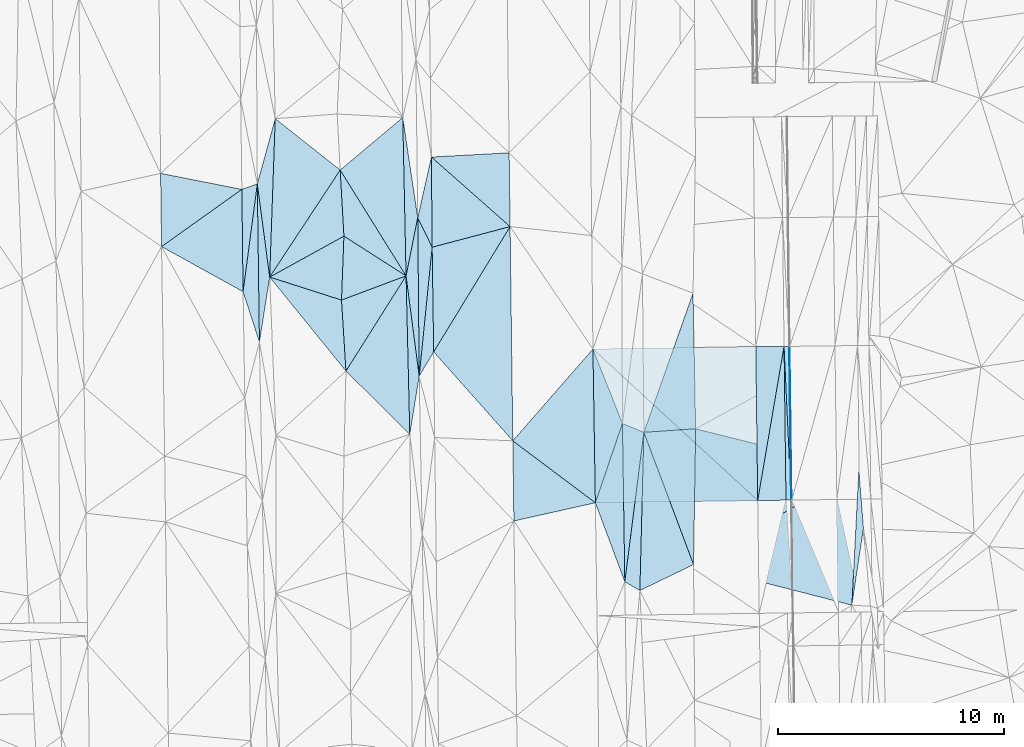
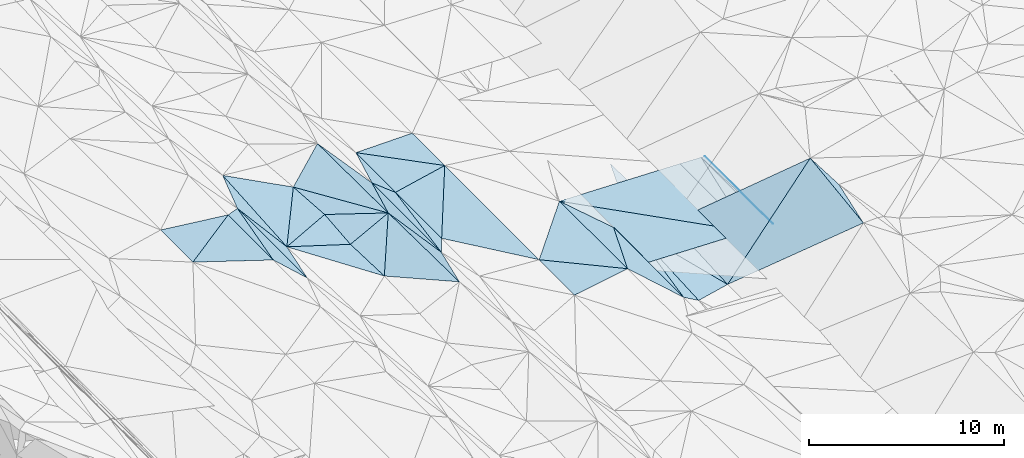
# One storey, part 33 of 275: 45 plates.
"""IFC2X3 building model written with IfcOpenShell, lengths in millimetres."""

from ifc_helpers import new_model, si_unit, frame, origin_with_axes, place, context, subcontext, project, spatial, polyline, outline, extrude, material, type_object, element, save


model = new_model("IFC2X3")

# Units and contexts
model_context = context("Model", 3, precision=1e-05, world=origin_with_axes())
body_context = subcontext(model_context, "Body", "Model", "MODEL_VIEW")
ifc_project = project(units=[si_unit("LENGTHUNIT", "METRE", prefix="MILLI"), si_unit("AREAUNIT", "SQUARE_METRE"), si_unit("VOLUMEUNIT", "CUBIC_METRE"), si_unit("MASSUNIT", "GRAM", prefix="KILO"), si_unit("TIMEUNIT", "SECOND"), si_unit("PLANEANGLEUNIT", "RADIAN"), si_unit("SOLIDANGLEUNIT", "STERADIAN"), si_unit("THERMODYNAMICTEMPERATUREUNIT", "DEGREE_CELSIUS"), si_unit("LUMINOUSINTENSITYUNIT", "LUMEN")], contexts=[model_context])

# Site, building, storey
site_placement = place(None, origin_with_axes())
site = spatial("IfcSite", under=ifc_project, at=site_placement, CompositionType="ELEMENT")
building_placement = place(site_placement, origin_with_axes())
building = spatial("IfcBuilding", under=site, at=building_placement, Name="Undefined", CompositionType="ELEMENT")
storey_placement = place(building_placement, origin_with_axes())
storey = spatial("IfcBuildingStorey", under=building, at=storey_placement, Name="Undefined", CompositionType="ELEMENT", Elevation=0.0)

# Plates
ifc_material = material()
plate_type_1 = type_object("IfcPlateType", PredefinedType="NOTDEFINED")
plate_1_placement = place(storey_placement, frame((-63085.534338525, 8684.36899878103, 41334.5004597078), z_axis=(-0.0369370970163898, 0.0225643102113344, -0.99906281222388), x_axis=(0.0150595045438115, -0.999618950249349, -0.0231336470381295)))
element("IfcPlate", 1, at=plate_1_placement, inside=storey, type_object=plate_type_1, material=ifc_material, Name="00", context=body_context, shape_type="SweptSolid", body=[
    extrude(outline(polyline([(0.0, 0.0), (7002.787109375, -1.11322151497006e-09), (3489.873046875, 1250.12219238281), (0.0, 0.0)])), frame((-8.85201319254618e-08, 2.18876761149539e-07, -0.5000001331573), z_axis=(0.0, 0.0, 1.0), x_axis=(1.0, 0.0, 0.0)), (0.0, 0.0, 1.0), 1.0),
])
plate_type_2 = type_object("IfcPlateType", PredefinedType="NOTDEFINED")
plate_2_placement = place(storey_placement, frame((-83458.0401202355, 16499.1899121102, 41559.5004170445), z_axis=(0.0371128799012044, 0.0190050586107432, -0.999130342794493), x_axis=(-0.0133932936564058, 0.999738796529341, 0.0185191360246058)))
element("IfcPlate", 2, at=plate_2_placement, inside=storey, type_object=plate_type_2, material=ifc_material, Name="00", context=body_context, shape_type="SweptSolid", body=[
    extrude(outline(polyline([(0.0, 0.0), (3239.89208984375, 3.44880390912294e-09), (2486.53344726563, 3585.64501953125), (0.0, 0.0)])), frame((-8.85201319254618e-08, 2.18876761149539e-07, -0.5000001331573), z_axis=(0.0, 0.0, 1.0), x_axis=(1.0, 0.0, 0.0)), (0.0, 0.0, 1.0), 1.0),
])
plate_type_3 = type_object("IfcPlateType", PredefinedType="NOTDEFINED")
plate_3_placement = place(storey_placement, frame((-55606.1009030587, 5293.94394170118, 40996.4907456072), z_axis=(-0.0501822086058736, 0.0211194130225013, -0.998516758163338), x_axis=(-0.0155081560633747, 0.999639384492585, 0.0219225469961935)))
element("IfcPlate", 3, at=plate_3_placement, inside=storey, type_object=plate_type_3, material=ifc_material, Name="00_PR", context=body_context, shape_type="SweptSolid", body=[
    extrude(outline(polyline([(0.0, 0.0), (6798.66259765625, 2.5029294192791e-09), (6798.5703125, 20.0249786376953), (0.0, 0.0)])), frame((-8.85201319254618e-08, 2.18876761149539e-07, -0.5000001331573), z_axis=(0.0, 0.0, 1.0), x_axis=(1.0, 0.0, 0.0)), (0.0, 0.0, 1.0), 1.0),
])
plate_4_placement = place(storey_placement, frame((-55606.1009030587, 5293.94394170118, 40996.4907456072), z_axis=(-0.0502069234273629, 0.0211190024140485, -0.998515524454675), x_axis=(-0.998666208743383, -0.0131185270511445, 0.0499370379790979)))
element("IfcPlate", 4, at=plate_4_placement, inside=storey, type_object=plate_type_3, material=ifc_material, Name="00_PR", context=body_context, shape_type="SweptSolid", body=[
    extrude(outline(polyline([(0.0, 0.0), (20.0252170562744, 7.18500814400613e-11), (23.5806293487549, 6798.62158203125), (0.0, 0.0)])), frame((-8.85201319254618e-08, 2.18876761149539e-07, -0.5000001331573), z_axis=(0.0, 0.0, 1.0), x_axis=(1.0, 0.0, 0.0)), (0.0, 0.0, 1.0), 1.0),
])
plate_type_4 = type_object("IfcPlateType", PredefinedType="NOTDEFINED")
plate_5_placement = place(storey_placement, frame((-57106.0315624464, 5279.47807770141, 41051.4944035738), z_axis=(-0.0338549393769678, 0.0212811578278257, -0.999200157826894), x_axis=(-0.0125651770635663, 0.999685189745127, 0.0217172219588593)))
element("IfcPlate", 5, at=plate_5_placement, inside=storey, type_object=plate_type_4, material=ifc_material, Name="00_PR", context=body_context, shape_type="SweptSolid", body=[
    extrude(outline(polyline([(0.0, 0.0), (6809.388671875, 3.63797880709171e-10), (6793.43310546875, 1250.69665527344), (0.0, 0.0)])), frame((-8.85201319254618e-08, 2.18876761149539e-07, -0.5000001331573), z_axis=(0.0, 0.0, 1.0), x_axis=(1.0, 0.0, 0.0)), (0.0, 0.0, 1.0), 1.0),
])
plate_type_5 = type_object("IfcPlateType", PredefinedType="NOTDEFINED")
plate_6_placement = place(storey_placement, frame((-55941.5115161613, 12087.3947260162, 41157.0344094784), z_axis=(-0.0341675188866801, 0.0213344424915223, -0.999188381746257), x_axis=(0.0125666940571451, -0.999683901046901, -0.0217755869754435)))
element("IfcPlate", 6, at=plate_6_placement, inside=storey, type_object=plate_type_5, material=ifc_material, Name="00_PR", context=body_context, shape_type="SweptSolid", body=[
    extrude(outline(polyline([(0.0, 0.0), (6798.88427734375, -6.12635631114244e-09), (6793.4287109375, 1250.72106933594), (0.0, 0.0)])), frame((-8.85201319254618e-08, 2.18876761149539e-07, -0.5000001331573), z_axis=(0.0, 0.0, 1.0), x_axis=(1.0, 0.0, 0.0)), (0.0, 0.0, 1.0), 1.0),
])
plate_type_6 = type_object("IfcPlateType", PredefinedType="NOTDEFINED")
plate_7_placement = place(storey_placement, frame((-55711.5356229066, 12090.1548382223, 41145.5347451969), z_axis=(-0.0501822086058736, 0.0211194130225013, -0.998516758163338), x_axis=(0.0125666940571451, -0.999683901046901, -0.0217755869754435)))
element("IfcPlate", 7, at=plate_7_placement, inside=storey, type_object=plate_type_6, material=ifc_material, Name="00_PR", context=body_context, shape_type="SweptSolid", body=[
    extrude(outline(polyline([(0.0, 0.0), (6798.62255859375, -1.54977897182107e-09), (-0.381209224462509, 230.287475585938), (0.0, 0.0)])), frame((-8.85201319254618e-08, 2.18876761149539e-07, -0.5000001331573), z_axis=(0.0, 0.0, 1.0), x_axis=(1.0, 0.0, 0.0)), (0.0, 0.0, 1.0), 1.0),
])
plate_8_placement = place(storey_placement, frame((-55856.0791666298, 5290.65935581579, 41008.9907460628), z_axis=(-0.0502076607453631, 0.0211181487987247, -0.99851550543484), x_axis=(-0.0125668220575414, 0.999683917691528, 0.0217747489605038)))
element("IfcPlate", 8, at=plate_8_placement, inside=storey, type_object=plate_type_6, material=ifc_material, Name="00_PR", context=body_context, shape_type="SweptSolid", body=[
    extrude(outline(polyline([(0.0, 0.0), (6798.88427734375, -6.12635631114244e-09), (-0.119594693183899, 230.286880493164), (0.0, 0.0)])), frame((-8.85201319254618e-08, 2.18876761149539e-07, -0.5000001331573), z_axis=(0.0, 0.0, 1.0), x_axis=(1.0, 0.0, 0.0)), (0.0, 0.0, 1.0), 1.0),
])
plate_type_7 = type_object("IfcPlateType", PredefinedType="NOTDEFINED")
plate_9_placement = place(storey_placement, frame((-64389.5860539135, 11972.8997140316, 41439.5003999853), z_axis=(-0.0336700774157678, 0.0212836155691658, -0.999206351858874), x_axis=(0.99931922283272, 0.0158024230601671, -0.0333372809694402)))
element("IfcPlate", 9, at=plate_9_placement, inside=storey, type_object=plate_type_7, material=ifc_material, Name="00_PR", context=body_context, shape_type="SweptSolid", body=[
    extrude(outline(polyline([(0.0, 0.0), (7202.89697265625, -1.26237864606082e-09), (7185.7587890625, 6809.3671875), (0.0, 0.0)])), frame((-8.85201319254618e-08, 2.18876761149539e-07, -0.5000001331573), z_axis=(0.0, 0.0, 1.0), x_axis=(1.0, 0.0, 0.0)), (0.0, 0.0, 1.0), 1.0),
])
plate_type_8 = type_object("IfcPlateType", PredefinedType="NOTDEFINED")
plate_10_placement = place(storey_placement, frame((-57106.0316977267, 5279.47783110151, 41051.4944029285), z_axis=(-0.0341252349844567, 0.020788038246301, -0.999201343975841), x_axis=(-0.999323625483583, -0.0144173130703921, 0.0338294639948438)))
element("IfcPlate", 10, at=plate_10_placement, inside=storey, type_object=plate_type_8, material=ifc_material, Name="00_PR", context=body_context, shape_type="SweptSolid", body=[
    extrude(outline(polyline([(0.0, 0.0), (7180.9296875, -1.59561750479043e-08), (7195.2529296875, 6799.333984375), (0.0, 0.0)])), frame((-8.85201319254618e-08, 2.18876761149539e-07, -0.5000001331573), z_axis=(0.0, 0.0, 1.0), x_axis=(1.0, 0.0, 0.0)), (0.0, 0.0, 1.0), 1.0),
])
plate_type_9 = type_object("IfcPlateType", PredefinedType="NOTDEFINED")
plate_11_placement = place(storey_placement, frame((-64389.5841732302, 11972.8991551249, 41439.5003133719), z_axis=(-0.0297436310834051, 0.0201138443502984, -0.999355166932871), x_axis=(0.368458731692333, -0.929170595276867, -0.0296676239781534)))
element("IfcPlate", 11, at=plate_11_placement, inside=storey, type_object=plate_type_9, material=ifc_material, Name="00", context=body_context, shape_type="SweptSolid", body=[
    extrude(outline(polyline([(0.0, 0.0), (3539.21166992188, -2.46654963120818e-09), (6359.28369140625, 2406.07861328125), (0.0, 0.0)])), frame((-8.85201319254618e-08, 2.18876761149539e-07, -0.5000001331573), z_axis=(0.0, 0.0, 1.0), x_axis=(1.0, 0.0, 0.0)), (0.0, 0.0, 1.0), 1.0),
])
plate_type_10 = type_object("IfcPlateType", PredefinedType="NOTDEFINED")
plate_12_placement = place(storey_placement, frame((-71429.2424392682, 11845.5865518244, 41659.50029753), z_axis=(-0.0293061238153869, 0.0196802600943957, -0.999376724998904), x_axis=(0.520744448360644, 0.853711218239636, 0.00154121814336699)))
element("IfcPlate", 12, at=plate_12_placement, inside=storey, type_object=plate_type_10, material=ifc_material, Name="00", context=body_context, shape_type="SweptSolid", body=[
    extrude(outline(polyline([(0.0, 0.0), (6488.3740234375, 7.42147676646709e-09), (-1534.66796875, 5036.80419921875), (0.0, 0.0)])), frame((-8.85201319254618e-08, 2.18876761149539e-07, -0.5000001331573), z_axis=(0.0, 0.0, 1.0), x_axis=(1.0, 0.0, 0.0)), (0.0, 0.0, 1.0), 1.0),
])
plate_type_11 = type_object("IfcPlateType", PredefinedType="NOTDEFINED")
plate_13_placement = place(storey_placement, frame((-72069.1854004757, 10773.21347745, 41660.5084277943), z_axis=(0.182006470566101, 0.0185295168551531, -0.983122729712413), x_axis=(-0.129940215574496, 0.991507297259225, -0.00536841300199027)))
element("IfcPlate", 13, at=plate_13_placement, inside=storey, type_object=plate_type_11, material=ifc_material, Name="00", context=body_context, shape_type="SweptSolid", body=[
    extrude(outline(polyline([(0.0, 0.0), (4470.5947265625, -5.17320586368442e-09), (6950.0556640625, 860.239990234375), (0.0, 0.0)])), frame((-8.85201319254618e-08, 2.18876761149539e-07, -0.5000001331573), z_axis=(0.0, 0.0, 1.0), x_axis=(1.0, 0.0, 0.0)), (0.0, 0.0, 1.0), 1.0),
])
plate_type_12 = type_object("IfcPlateType", PredefinedType="NOTDEFINED")
plate_14_placement = place(storey_placement, frame((-79854.4320262508, 14506.0956215983, 41639.500168743), z_axis=(0.0156607527350185, 0.0222808532478277, -0.999629083411603), x_axis=(-0.0119464226664534, 0.999684498778123, 0.0220949290156476)))
element("IfcPlate", 14, at=plate_14_placement, inside=storey, type_object=plate_type_12, material=ifc_material, Name="00", context=body_context, shape_type="SweptSolid", body=[
    extrude(outline(polyline([(0.0, 0.0), (4525.92529296875, -4.13274392485619e-09), (4755.61083984375, 686.165100097656), (0.0, 0.0)])), frame((-8.85201319254618e-08, 2.18876761149539e-07, -0.5000001331573), z_axis=(0.0, 0.0, 1.0), x_axis=(1.0, 0.0, 0.0)), (0.0, 0.0, 1.0), 1.0),
])
plate_type_13 = type_object("IfcPlateType", PredefinedType="NOTDEFINED")
plate_15_placement = place(storey_placement, frame((-52943.4534964903, 649.111417036266, 42936.5007921276), z_axis=(-0.0183788980974422, 0.0536330072608011, -0.998391564786525), x_axis=(0.0514689023508599, 0.997287037128105, 0.0526262070364499)))
element("IfcPlate", 15, at=plate_15_placement, inside=storey, type_object=plate_type_13, material=ifc_material, Name="00", context=body_context, shape_type="SweptSolid", body=[
    extrude(outline(polyline([(0.0, 0.0), (6004.61279296875, -1.19325704872608e-09), (3421.61547851563, 335.0791015625), (0.0, 0.0)])), frame((-8.85201319254618e-08, 2.18876761149539e-07, -0.5000001331573), z_axis=(0.0, 0.0, 1.0), x_axis=(1.0, 0.0, 0.0)), (0.0, 0.0, 1.0), 1.0),
])
plate_type_14 = type_object("IfcPlateType", PredefinedType="NOTDEFINED")
plate_16_placement = place(storey_placement, frame((-71496.3066648247, 16473.6746332651, 41749.5002758741), z_axis=(-0.0282335174220587, 0.0190260740692208, -0.999420270456574), x_axis=(0.966533054055638, 0.255558859707056, -0.0224393547837469)))
element("IfcPlate", 16, at=plate_16_placement, inside=storey, type_object=plate_type_14, material=ifc_material, Name="00", context=body_context, shape_type="SweptSolid", body=[
    extrude(outline(polyline([(0.0, 0.0), (3565.16479492188, -1.13504938781261e-09), (-1115.9091796875, 4492.9443359375), (0.0, 0.0)])), frame((-8.85201319254618e-08, 2.18876761149539e-07, -0.5000001331573), z_axis=(0.0, 0.0, 1.0), x_axis=(1.0, 0.0, 0.0)), (0.0, 0.0, 1.0), 1.0),
])
plate_type_15 = type_object("IfcPlateType", PredefinedType="NOTDEFINED")
plate_17_placement = place(storey_placement, frame((-78678.5249739628, 15152.7962430898, 41661.5002095248), z_axis=(-0.0220739810846482, 0.0198987167112959, -0.999558292663474), x_axis=(-0.131654518554041, 0.991037172027586, 0.0226365059995845)))
element("IfcPlate", 17, at=plate_17_placement, inside=storey, type_object=plate_type_15, material=ifc_material, Name="00", context=body_context, shape_type="SweptSolid", body=[
    extrude(outline(polyline([(0.0, 0.0), (4152.58447265625, -2.6338966563344e-09), (6911.16357421875, 1165.56665039063), (0.0, 0.0)])), frame((-8.85201319254618e-08, 2.18876761149539e-07, -0.5000001331573), z_axis=(0.0, 0.0, 1.0), x_axis=(1.0, 0.0, 0.0)), (0.0, 0.0, 1.0), 1.0),
])
plate_type_16 = type_object("IfcPlateType", PredefinedType="NOTDEFINED")
plate_18_placement = place(storey_placement, frame((-72069.293060822, 10773.2136927695, 41660.5003531147), z_axis=(-0.0333102560253779, 0.018949496162916, -0.999265401902165), x_axis=(0.0999993363783862, 0.994866257547555, 0.0155326210667701)))
element("IfcPlate", 18, at=plate_18_placement, inside=storey, type_object=plate_type_16, material=ifc_material, Name="00", context=body_context, shape_type="SweptSolid", body=[
    extrude(outline(polyline([(0.0, 0.0), (5729.87646484375, -3.78349795937538e-09), (1130.85607910156, 529.91552734375), (0.0, 0.0)])), frame((-8.85201319254618e-08, 2.18876761149539e-07, -0.5000001331573), z_axis=(0.0, 0.0, 1.0), x_axis=(1.0, 0.0, 0.0)), (0.0, 0.0, 1.0), 1.0),
])
plate_type_17 = type_object("IfcPlateType", PredefinedType="NOTDEFINED")
plate_19_placement = place(storey_placement, frame((-59849.5582576572, 8447.63962534401, 40652.5106788933), z_axis=(-0.20254727770208, 0.0355374176027969, -0.978627453245412), x_axis=(-0.0152652204527903, -0.999334469653733, -0.0331299080351765)))
element("IfcPlate", 19, at=plate_19_placement, inside=storey, type_object=plate_type_17, material=ifc_material, Name="00", context=body_context, shape_type="SweptSolid", body=[
    extrude(outline(polyline([(0.0, 0.0), (6006.6572265625, -3.71073838323355e-09), (174.953384399414, 2334.4892578125), (0.0, 0.0)])), frame((-8.85201319254618e-08, 2.18876761149539e-07, -0.5000001331573), z_axis=(0.0, 0.0, 1.0), x_axis=(1.0, 0.0, 0.0)), (0.0, 0.0, 1.0), 1.0),
])
plate_type_18 = type_object("IfcPlateType", PredefinedType="NOTDEFINED")
plate_20_placement = place(storey_placement, frame((-79131.5365787582, 12274.8692533166, 41612.5001898718), z_axis=(-0.0200263350420128, 0.0201715959286534, -0.999595944680888), x_axis=(-0.0133936735424026, 0.999701321302467, 0.0204420570183296)))
element("IfcPlate", 20, at=plate_20_placement, inside=storey, type_object=plate_type_18, material=ifc_material, Name="00", context=body_context, shape_type="SweptSolid", body=[
    extrude(outline(polyline([(0.0, 0.0), (6995.3818359375, -9.45874489843845e-10), (2872.00170898438, 491.621978759766), (0.0, 0.0)])), frame((-8.85201319254618e-08, 2.18876761149539e-07, -0.5000001331573), z_axis=(0.0, 0.0, 1.0), x_axis=(1.0, 0.0, 0.0)), (0.0, 0.0, 1.0), 1.0),
])
plate_type_19 = type_object("IfcPlateType", PredefinedType="NOTDEFINED")
plate_21_placement = place(storey_placement, frame((-79225.2070081375, 19268.1621804227, 41755.5002754346), z_axis=(0.0268588396974892, 0.0207962096628469, -0.999422893671024), x_axis=(0.0133936735155429, -0.999701321303435, -0.0204420569886023)))
element("IfcPlate", 21, at=plate_21_placement, inside=storey, type_object=plate_type_19, material=ifc_material, Name="00", context=body_context, shape_type="SweptSolid", body=[
    extrude(outline(polyline([(0.0, 0.0), (6995.3818359375, -9.45874489843845e-10), (4754.5888671875, 693.213134765625), (0.0, 0.0)])), frame((-8.85201319254618e-08, 2.18876761149539e-07, -0.5000001331573), z_axis=(0.0, 0.0, 1.0), x_axis=(1.0, 0.0, 0.0)), (0.0, 0.0, 1.0), 1.0),
])
plate_type_20 = type_object("IfcPlateType", PredefinedType="NOTDEFINED")
plate_22_placement = place(storey_placement, frame((-72484.8295077743, 8201.54507200805, 41516.5107588047), z_axis=(0.205296130925048, 0.0216069404373172, -0.978461362932714), x_axis=(-0.0235832505463294, 0.999575191040927, 0.0171250620192308)))
element("IfcPlate", 22, at=plate_22_placement, inside=storey, type_object=plate_type_20, material=ifc_material, Name="00", context=body_context, shape_type="SweptSolid", body=[
    extrude(outline(polyline([(0.0, 0.0), (7007.27392578125, -2.64844857156277e-09), (2563.24096679688, 486.6083984375), (0.0, 0.0)])), frame((-8.85201319254618e-08, 2.18876761149539e-07, -0.5000001331573), z_axis=(0.0, 0.0, 1.0), x_axis=(1.0, 0.0, 0.0)), (0.0, 0.0, 1.0), 1.0),
])
plate_type_21 = type_object("IfcPlateType", PredefinedType="NOTDEFINED")
plate_23_placement = place(storey_placement, frame((-59964.6036930516, 14443.0792287991, 40761.5102695677), z_axis=(-0.20124539325043, 0.0139450140627032, -0.979441590028865), x_axis=(0.0191821964893445, -0.999650811674886, -0.0181741039830456)))
element("IfcPlate", 23, at=plate_23_placement, inside=storey, type_object=plate_type_21, material=ifc_material, Name="00", context=body_context, shape_type="SweptSolid", body=[
    extrude(outline(polyline([(0.0, 0.0), (5997.54443359375, -4.80213202536106e-10), (6100.7138671875, 2338.76147460938), (0.0, 0.0)])), frame((-8.85201319254618e-08, 2.18876761149539e-07, -0.5000001331573), z_axis=(0.0, 0.0, 1.0), x_axis=(1.0, 0.0, 0.0)), (0.0, 0.0, 1.0), 1.0),
])
plate_type_22 = type_object("IfcPlateType", PredefinedType="NOTDEFINED")
plate_24_placement = place(storey_placement, frame((-75504.037272346, 14137.724360508, 41319.5026273024), z_axis=(-0.094043313671562, 0.0410333595514505, -0.994722131329948), x_axis=(0.0622192225208152, -0.996954880651629, -0.0470078109871342)))
element("IfcPlate", 24, at=plate_24_placement, inside=storey, type_object=plate_type_22, material=ifc_material, Name="00", context=body_context, shape_type="SweptSolid", body=[
    extrude(outline(polyline([(0.0, 0.0), (3148.41284179688, 1.99361238628626e-09), (-1225.58447265625, 3118.15649414063), (0.0, 0.0)])), frame((-8.85201319254618e-08, 2.18876761149539e-07, -0.5000001331573), z_axis=(0.0, 0.0, 1.0), x_axis=(1.0, 0.0, 0.0)), (0.0, 0.0, 1.0), 1.0),
])
plate_type_23 = type_object("IfcPlateType", PredefinedType="NOTDEFINED")
plate_25_placement = place(storey_placement, frame((-62980.1636764046, 1684.24889227149, 41172.5115172295), z_axis=(-0.212600057881091, 0.0194060804486137, -0.976946579619673), x_axis=(-0.0150595045538727, 0.999618950250185, 0.0231336469954438)))
element("IfcPlate", 25, at=plate_25_placement, inside=storey, type_object=plate_type_23, material=ifc_material, Name="00", context=body_context, shape_type="SweptSolid", body=[
    extrude(outline(polyline([(0.0, 0.0), (7002.787109375, -1.11322151497006e-09), (6591.3525390625, 963.507080078125), (0.0, 0.0)])), frame((-8.85201319254618e-08, 2.18876761149539e-07, -0.5000001331573), z_axis=(0.0, 0.0, 1.0), x_axis=(1.0, 0.0, 0.0)), (0.0, 0.0, 1.0), 1.0),
])
plate_type_24 = type_object("IfcPlateType", PredefinedType="NOTDEFINED")
plate_26_placement = place(storey_placement, frame((-72650.1081175779, 15205.8435217715, 41636.5063085416), z_axis=(0.156677870740202, 0.0238569222979481, -0.987361581224825), x_axis=(-0.0208156475431547, 0.999565925843796, 0.0208487100175156)))
element("IfcPlate", 26, at=plate_26_placement, inside=storey, type_object=plate_type_24, material=ifc_material, Name="00", context=body_context, shape_type="SweptSolid", body=[
    extrude(outline(polyline([(0.0, 0.0), (7002.8310546875, -4.00905264541507e-09), (2560.27758789063, 576.815979003906), (0.0, 0.0)])), frame((-8.85201319254618e-08, 2.18876761149539e-07, -0.5000001331573), z_axis=(0.0, 0.0, 1.0), x_axis=(1.0, 0.0, 0.0)), (0.0, 0.0, 1.0), 1.0),
])
plate_type_25 = type_object("IfcPlateType", PredefinedType="NOTDEFINED")
plate_27_placement = place(storey_placement, frame((-62138.082034099, 8292.00736579458, 41120.5176247738), z_axis=(-0.261956410787184, 0.0257922584598766, -0.964734988611398), x_axis=(-0.0252625814544928, -0.999483524766561, -0.0198616640407225)))
element("IfcPlate", 27, at=plate_27_placement, inside=storey, type_object=plate_type_25, material=ifc_material, Name="00", context=body_context, shape_type="SweptSolid", body=[
    extrude(outline(polyline([(0.0, 0.0), (6998.40673828125, -4.39467839896679e-09), (6624.58349609375, 699.407043457031), (0.0, 0.0)])), frame((-8.85201319254618e-08, 2.18876761149539e-07, -0.5000001331573), z_axis=(0.0, 0.0, 1.0), x_axis=(1.0, 0.0, 0.0)), (0.0, 0.0, 1.0), 1.0),
])
plate_type_26 = type_object("IfcPlateType", PredefinedType="NOTDEFINED")
plate_28_placement = place(storey_placement, frame((-72133.9185815669, 17774.9786993754, 41780.5001016621), z_axis=(-0.007797963871655, 0.0199958753442322, -0.999769651834199), x_axis=(0.219018831395588, 0.975558195381218, 0.0178033400981889)))
element("IfcPlate", 28, at=plate_28_placement, inside=storey, type_object=plate_type_26, material=ifc_material, Name="00", context=body_context, shape_type="SweptSolid", body=[
    extrude(outline(polyline([(0.0, 0.0), (2752.29248046875, -6.37373887002468e-09), (-1130.39807128906, 907.256469726563), (0.0, 0.0)])), frame((-8.85201319254618e-08, 2.18876761149539e-07, -0.5000001331573), z_axis=(0.0, 0.0, 1.0), x_axis=(1.0, 0.0, 0.0)), (0.0, 0.0, 1.0), 1.0),
])
plate_29_placement = place(storey_placement, frame((-72069.2833503895, 10773.2127163934, 41660.5001103939), z_axis=(-0.0138991992444694, 0.0170060897767567, -0.999758773490319), x_axis=(-0.00922996353593435, 0.999810576846857, 0.0171352910182584)))
element("IfcPlate", 29, at=plate_29_placement, inside=storey, type_object=plate_type_26, material=ifc_material, Name="00", context=body_context, shape_type="SweptSolid", body=[
    extrude(outline(polyline([(0.0, 0.0), (7003.0908203125, -2.88127921521664e-09), (5695.61767578125, 625.641296386719), (0.0, 0.0)])), frame((-8.85201319254618e-08, 2.18876761149539e-07, -0.5000001331573), z_axis=(0.0, 0.0, 1.0), x_axis=(1.0, 0.0, 0.0)), (0.0, 0.0, 1.0), 1.0),
])
plate_type_27 = type_object("IfcPlateType", PredefinedType="NOTDEFINED")
plate_30_placement = place(storey_placement, frame((-72650.1482992659, 15205.8339314015, 41636.5014534521), z_axis=(0.0763144337501521, 0.00467212943144426, -0.997072855115397), x_axis=(-0.840873727600138, 0.537686924758309, -0.0618396731540566)))
element("IfcPlate", 30, at=plate_30_placement, inside=storey, type_object=plate_type_27, material=ifc_material, Name="00", context=body_context, shape_type="SweptSolid", body=[
    extrude(outline(polyline([(0.0, 0.0), (3266.51147460938, 1.94850144907832e-08), (4977.30224609375, 2375.22534179688), (0.0, 0.0)])), frame((-8.85201319254618e-08, 2.18876761149539e-07, -0.5000001331573), z_axis=(0.0, 0.0, 1.0), x_axis=(1.0, 0.0, 0.0)), (0.0, 0.0, 1.0), 1.0),
])
plate_type_28 = type_object("IfcPlateType", PredefinedType="NOTDEFINED")
plate_31_placement = place(storey_placement, frame((-59940.9776160488, 2444.97517443615, 40453.5308016046), z_axis=(0.344636405349566, 0.0258447064803014, -0.938380412868191), x_axis=(0.0152652204341512, 0.999334469655401, 0.0331299079934578)))
element("IfcPlate", 31, at=plate_31_placement, inside=storey, type_object=plate_type_28, material=ifc_material, Name="00", context=body_context, shape_type="SweptSolid", body=[
    extrude(outline(polyline([(0.0, 0.0), (6006.6572265625, -3.71073838323355e-09), (4393.9248046875, 7713.177734375), (0.0, 0.0)])), frame((-8.85201319254618e-08, 2.18876761149539e-07, -0.5000001331573), z_axis=(0.0, 0.0, 1.0), x_axis=(1.0, 0.0, 0.0)), (0.0, 0.0, 1.0), 1.0),
])
plate_type_29 = type_object("IfcPlateType", PredefinedType="NOTDEFINED")
plate_32_placement = place(storey_placement, frame((-71531.1250169468, 20460.0001101576, 41829.5002864684), z_axis=(-0.0284398149080996, 0.0198081472055541, -0.99939922665183), x_axis=(0.748962092403894, -0.661717815454872, -0.0344284308618987)))
element("IfcPlate", 32, at=plate_32_placement, inside=storey, type_object=plate_type_29, material=ifc_material, Name="00", context=body_context, shape_type="SweptSolid", body=[
    extrude(outline(polyline([(0.0, 0.0), (4647.32177734375, 4.522007657215e-09), (2666.65405273438, 2964.34741210938), (0.0, 0.0)])), frame((-8.85201319254618e-08, 2.18876761149539e-07, -0.5000001331573), z_axis=(0.0, 0.0, 1.0), x_axis=(1.0, 0.0, 0.0)), (0.0, 0.0, 1.0), 1.0),
])
plate_type_30 = type_object("IfcPlateType", PredefinedType="NOTDEFINED")
plate_33_placement = place(storey_placement, frame((-75503.9419039288, 14137.7222568826, 41319.5026732875), z_axis=(0.0966984288719946, 0.0368308148610942, -0.994632044994708), x_axis=(0.0378528114689956, 0.99845607845869, 0.0406524790484716)))
element("IfcPlate", 33, at=plate_33_placement, inside=storey, type_object=plate_type_30, material=ifc_material, Name="00", context=body_context, shape_type="SweptSolid", body=[
    extrude(outline(polyline([(0.0, 0.0), (2828.85571289063, 1.13504938781261e-09), (1187.39001464844, 2824.1259765625), (0.0, 0.0)])), frame((-8.85201319254618e-08, 2.18876761149539e-07, -0.5000001331573), z_axis=(0.0, 0.0, 1.0), x_axis=(1.0, 0.0, 0.0)), (0.0, 0.0, 1.0), 1.0),
])
plate_type_31 = type_object("IfcPlateType", PredefinedType="NOTDEFINED")
plate_34_placement = place(storey_placement, frame((-79908.4911570215, 19030.5931139352, 41739.5004096329), z_axis=(0.0346235505918886, 0.0224968115450813, -0.999147187963173), x_axis=(0.0119464226601176, -0.999684498777979, -0.0220949290256085)))
element("IfcPlate", 34, at=plate_34_placement, inside=storey, type_object=plate_type_31, material=ifc_material, Name="00", context=body_context, shape_type="SweptSolid", body=[
    extrude(outline(polyline([(0.0, 0.0), (4525.92529296875, -4.13274392485619e-09), (2492.17553710938, 3581.72607421875), (0.0, 0.0)])), frame((-8.85201319254618e-08, 2.18876761149539e-07, -0.5000001331573), z_axis=(0.0, 0.0, 1.0), x_axis=(1.0, 0.0, 0.0)), (0.0, 0.0, 1.0), 1.0),
])
plate_type_32 = type_object("IfcPlateType", PredefinedType="NOTDEFINED")
plate_35_placement = place(storey_placement, frame((-67930.9651860956, 7914.39909435939, 41479.5003764578), z_axis=(-0.0326867579584146, 0.0221257537095039, -0.999220709791863), x_axis=(0.799188332318063, -0.599786405394718, -0.0394243248560645)))
element("IfcPlate", 35, at=plate_35_placement, inside=storey, type_object=plate_type_32, material=ifc_material, Name="00", context=body_context, shape_type="SweptSolid", body=[
    extrude(outline(polyline([(0.0, 0.0), (4565.708984375, 3.76167008653283e-09), (2166.0380859375, 2806.13232421875), (0.0, 0.0)])), frame((-8.85201319254618e-08, 2.18876761149539e-07, -0.5000001331573), z_axis=(0.0, 0.0, 1.0), x_axis=(1.0, 0.0, 0.0)), (0.0, 0.0, 1.0), 1.0),
])
plate_type_33 = type_object("IfcPlateType", PredefinedType="NOTDEFINED")
plate_36_placement = place(storey_placement, frame((-71531.1258174172, 20459.9992030203, 41829.5002933987), z_axis=(-0.0300403846048648, 0.0179958970516631, -0.999386673406294), x_axis=(0.998116605121861, 0.054042163678577, -0.0290290737872983)))
element("IfcPlate", 36, at=plate_36_placement, inside=storey, type_object=plate_type_33, material=ifc_material, Name="00", context=body_context, shape_type="SweptSolid", body=[
    extrude(outline(polyline([(0.0, 0.0), (3444.822265625, -4.29281499236822e-09), (3312.56567382813, 3259.52587890625), (0.0, 0.0)])), frame((-8.85201319254618e-08, 2.18876761149539e-07, -0.5000001331573), z_axis=(0.0, 0.0, 1.0), x_axis=(1.0, 0.0, 0.0)), (0.0, 0.0, 1.0), 1.0),
])
plate_type_34 = type_object("IfcPlateType", PredefinedType="NOTDEFINED")
plate_37_placement = place(storey_placement, frame((-64389.5864292646, 11972.8991183258, 41439.5003845184), z_axis=(-0.0342519819937498, 0.0200396100248308, -0.999212297642274), x_axis=(0.0158079285406111, -0.999663012974668, -0.0205905290282536)))
element("IfcPlate", 37, at=plate_37_placement, inside=storey, type_object=plate_type_34, material=ifc_material, Name="00", context=body_context, shape_type="SweptSolid", body=[
    extrude(outline(polyline([(0.0, 0.0), (6799.24267578125, -1.52795109897852e-09), (4000.32788085938, 3607.18408203125), (0.0, 0.0)])), frame((-8.85201319254618e-08, 2.18876761149539e-07, -0.5000001331573), z_axis=(0.0, 0.0, 1.0), x_axis=(1.0, 0.0, 0.0)), (0.0, 0.0, 1.0), 1.0),
])
plate_type_35 = type_object("IfcPlateType", PredefinedType="NOTDEFINED")
plate_38_placement = place(storey_placement, frame((-62138.0653701965, 8292.00702852105, 41120.5133973843), z_axis=(-0.228628934533615, 0.025117892938918, -0.973189550780491), x_axis=(0.349719501539878, -0.930817620861966, -0.106182987976272)))
element("IfcPlate", 38, at=plate_38_placement, inside=storey, type_object=plate_type_35, material=ifc_material, Name="00", context=body_context, shape_type="SweptSolid", body=[
    extrude(outline(polyline([(0.0, 0.0), (6281.60888671875, 1.52067514136434e-09), (6463.8056640625, 2682.70629882813), (0.0, 0.0)])), frame((-8.85201319254618e-08, 2.18876761149539e-07, -0.5000001331573), z_axis=(0.0, 0.0, 1.0), x_axis=(1.0, 0.0, 0.0)), (0.0, 0.0, 1.0), 1.0),
])
plate_type_36 = type_object("IfcPlateType", PredefinedType="NOTDEFINED")
plate_39_placement = place(storey_placement, frame((-75308.0530512959, 10998.9044818151, 41171.5027483373), z_axis=(0.0907954474714362, 0.0525576749513888, -0.994481713015461), x_axis=(-0.0622192225222664, 0.996954880650939, 0.0470078109998306)))
element("IfcPlate", 39, at=plate_39_placement, inside=storey, type_object=plate_type_36, material=ifc_material, Name="00", context=body_context, shape_type="SweptSolid", body=[
    extrude(outline(polyline([(0.0, 0.0), (3148.41284179688, 1.99361238628626e-09), (4050.62817382813, 2927.72778320313), (0.0, 0.0)])), frame((-8.85201319254618e-08, 2.18876761149539e-07, -0.5000001331573), z_axis=(0.0, 0.0, 1.0), x_axis=(1.0, 0.0, 0.0)), (0.0, 0.0, 1.0), 1.0),
])
plate_type_37 = type_object("IfcPlateType", PredefinedType="NOTDEFINED")
plate_40_placement = place(storey_placement, frame((-75562.819515704, 19884.7009868991, 41435.5029709113), z_axis=(-0.106660572168759, 0.0227552221484947, -0.99403507091531), x_axis=(-0.549506312555612, -0.834538272287407, 0.0398583058983248)))
element("IfcPlate", 40, at=plate_40_placement, inside=storey, type_object=plate_type_37, material=ifc_material, Name="00", context=body_context, shape_type="SweptSolid", body=[
    extrude(outline(polyline([(0.0, 0.0), (5670.08544921875, -2.8085196390748e-09), (-303.766662597656, 3665.490234375), (0.0, 0.0)])), frame((-8.85201319254618e-08, 2.18876761149539e-07, -0.5000001331573), z_axis=(0.0, 0.0, 1.0), x_axis=(1.0, 0.0, 0.0)), (0.0, 0.0, 1.0), 1.0),
])
plate_type_38 = type_object("IfcPlateType", PredefinedType="NOTDEFINED")
plate_41_placement = place(storey_placement, frame((-72650.1159348668, 15205.8417480054, 41636.5050915481), z_axis=(0.141055893985402, 0.020285453827789, -0.989793784146465), x_axis=(0.0235832505122738, -0.999575191042398, -0.0171250619802794)))
element("IfcPlate", 41, at=plate_41_placement, inside=storey, type_object=plate_type_38, material=ifc_material, Name="00", context=body_context, shape_type="SweptSolid", body=[
    extrude(outline(polyline([(0.0, 0.0), (7007.27392578125, -2.64844857156277e-09), (4150.447265625, 2784.41479492188), (0.0, 0.0)])), frame((-8.85201319254618e-08, 2.18876761149539e-07, -0.5000001331573), z_axis=(0.0, 0.0, 1.0), x_axis=(1.0, 0.0, 0.0)), (0.0, 0.0, 1.0), 1.0),
])
plate_type_39 = type_object("IfcPlateType", PredefinedType="NOTDEFINED")
plate_42_placement = place(storey_placement, frame((-72650.133733659, 15205.8430593658, 41636.5029094106), z_axis=(0.105446439757171, 0.0229318549222001, -0.994160539536932), x_axis=(-0.528119546609598, 0.848387546967266, -0.0364460510856483)))
element("IfcPlate", 42, at=plate_42_placement, inside=storey, type_object=plate_type_39, material=ifc_material, Name="00", context=body_context, shape_type="SweptSolid", body=[
    extrude(outline(polyline([(0.0, 0.0), (5515.0009765625, 5.82076609134674e-09), (6010.1982421875, 3594.0458984375), (0.0, 0.0)])), frame((-8.85201319254618e-08, 2.18876761149539e-07, -0.5000001331573), z_axis=(0.0, 0.0, 1.0), x_axis=(1.0, 0.0, 0.0)), (0.0, 0.0, 1.0), 1.0),
])
plate_type_40 = type_object("IfcPlateType", PredefinedType="NOTDEFINED")
plate_43_placement = place(storey_placement, frame((-78678.5604772495, 15152.8083075196, 41661.5026463746), z_axis=(-0.0930817723569329, 0.0440277751494508, -0.994684542289806), x_axis=(0.874103426080002, 0.481961834657039, -0.0604647868533719)))
element("IfcPlate", 43, at=plate_43_placement, inside=storey, type_object=plate_type_40, material=ifc_material, Name="00", context=body_context, shape_type="SweptSolid", body=[
    extrude(outline(polyline([(0.0, 0.0), (3754.25122070313, -6.2791514210403e-09), (2306.31005859375, 2430.20385742188), (0.0, 0.0)])), frame((-8.85201319254618e-08, 2.18876761149539e-07, -0.5000001331573), z_axis=(0.0, 0.0, 1.0), x_axis=(1.0, 0.0, 0.0)), (0.0, 0.0, 1.0), 1.0),
])
plate_type_41 = type_object("IfcPlateType", PredefinedType="NOTDEFINED")
plate_44_placement = place(storey_placement, frame((-75562.7997473928, 19884.6878825429, 41435.5011170856), z_axis=(-0.0671055548672838, -0.0034669406341492, -0.997739858294031), x_axis=(0.056660312473435, -0.9983934556497, -0.000341622983575855)))
element("IfcPlate", 44, at=plate_44_placement, inside=storey, type_object=plate_type_41, material=ifc_material, Name="00", context=body_context, shape_type="SweptSolid", body=[
    extrude(outline(polyline([(0.0, 0.0), (2927.2001953125, -3.46335582435131e-09), (4547.68505859375, 3386.50732421875), (0.0, 0.0)])), frame((-8.85201319254618e-08, 2.18876761149539e-07, -0.5000001331573), z_axis=(0.0, 0.0, 1.0), x_axis=(1.0, 0.0, 0.0)), (0.0, 0.0, 1.0), 1.0),
])
plate_type_42 = type_object("IfcPlateType", PredefinedType="NOTDEFINED")
plate_45_placement = place(storey_placement, frame((-52634.2227691916, 6637.42317403769, 43252.5303248776), z_axis=(0.341503616619318, 0.031943613742807, -0.9393374715069), x_axis=(-0.051468902439864, -0.997287037124711, -0.0526262070137138)))
element("IfcPlate", 45, at=plate_45_placement, inside=storey, type_object=plate_type_42, material=ifc_material, Name="00", context=body_context, shape_type="SweptSolid", body=[
    extrude(outline(polyline([(0.0, 0.0), (6004.61279296875, -1.19325704872608e-09), (4704.4423828125, 7527.80908203125), (0.0, 0.0)])), frame((-8.85201319254618e-08, 2.18876761149539e-07, -0.5000001331573), z_axis=(0.0, 0.0, 1.0), x_axis=(1.0, 0.0, 0.0)), (0.0, 0.0, 1.0), 1.0),
])

save(model, "model.ifc")
